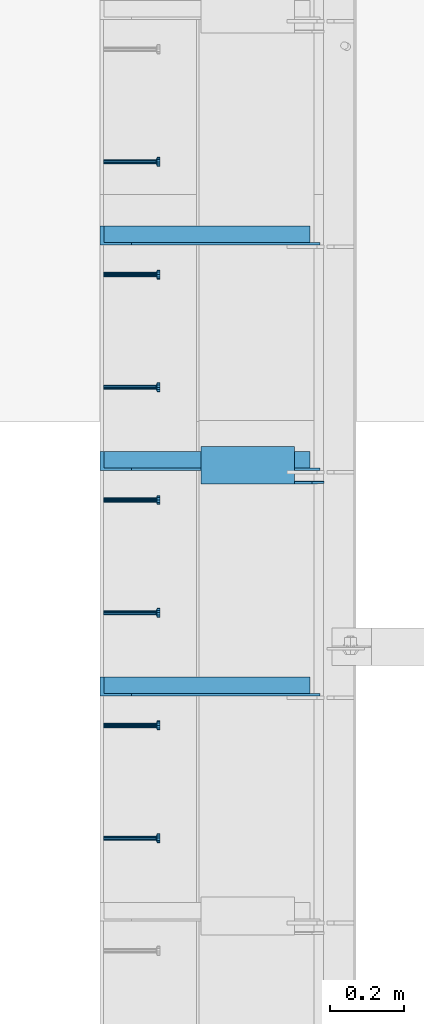
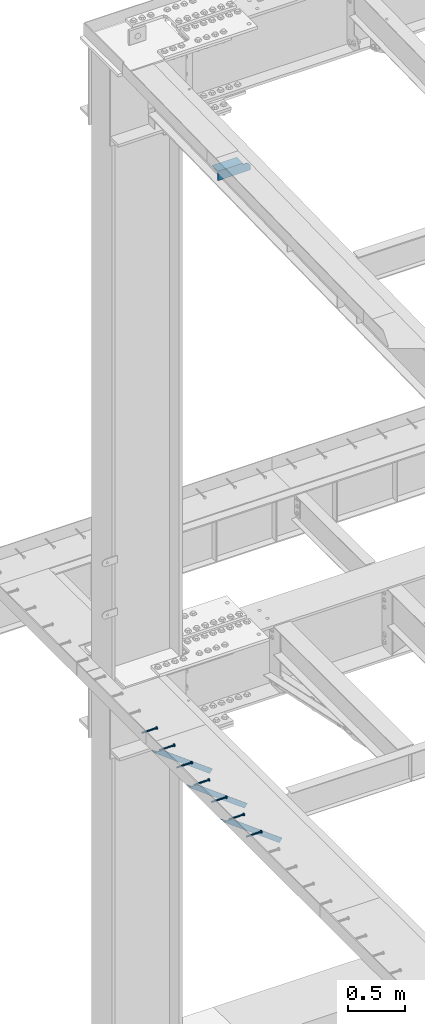
# One storey, part 1331 of 1763: 8 beams, 3 members, 9 elements without a shape of their own.
"""IFC2X3 building model written with IfcOpenShell, lengths in millimetres."""

from ifc_helpers import new_model, si_unit, frame, origin_with_axes, place, context, subcontext, project, spatial, faceted_brep, material, type_object, element, aggregate, save


model = new_model("IFC2X3")

# Units and contexts
model_context = context("Model", 3, precision=1e-05, world=origin_with_axes())
body_context = subcontext(model_context, "Body", "Model", "MODEL_VIEW")
ifc_project = project(units=[si_unit("LENGTHUNIT", "METRE", prefix="MILLI"), si_unit("AREAUNIT", "SQUARE_METRE"), si_unit("VOLUMEUNIT", "CUBIC_METRE"), si_unit("MASSUNIT", "GRAM", prefix="KILO"), si_unit("TIMEUNIT", "SECOND"), si_unit("PLANEANGLEUNIT", "RADIAN"), si_unit("SOLIDANGLEUNIT", "STERADIAN"), si_unit("THERMODYNAMICTEMPERATUREUNIT", "DEGREE_CELSIUS"), si_unit("LUMINOUSINTENSITYUNIT", "LUMEN")], contexts=[model_context])

# Site, building, storey
site_placement = place(None, origin_with_axes())
site = spatial("IfcSite", under=ifc_project, at=site_placement, CompositionType="ELEMENT")
building_placement = place(site_placement, origin_with_axes())
building = spatial("IfcBuilding", under=site, at=building_placement, Name="Undefined", CompositionType="ELEMENT")
storey_placement = place(building_placement, origin_with_axes())
storey = spatial("IfcBuildingStorey", under=building, at=storey_placement, Name="Undefined", CompositionType="ELEMENT", Elevation=0.0)

# Assembly, beam
assembly_1_placement = place(storey_placement, origin_with_axes())
assembly_1 = element("IfcElementAssembly", 1, at=assembly_1_placement, inside=storey, Name="HEADED STUD ANCHOR", AssemblyPlace="NOTDEFINED", PredefinedType="RIGID_FRAME")
ifc_material_1 = material(Name="STEEL/A108")
beam_type_1 = type_object("IfcBeamType", PredefinedType="NOTDEFINED")
beam_1_placement = place(assembly_1_placement, frame((-87975.5122736983, 49164.8750061035, 5268.91250001202), z_axis=(0.0, 0.0, -1.0), x_axis=(1.0, 0.0, 0.0)))
beam_1 = element("IfcBeam", 2, at=beam_1_placement, type_object=beam_type_1, material=ifc_material_1, Name="HEADED STUD ANCHOR", context=body_context, shape_type="Brep", body=[
    faceted_brep([(0.0, -3.1800000667572, 5.5), (0.0, -5.5, 3.1800000667572), (141.732000000002, -5.5, 3.1800000667572), (141.732000000002, -3.1800000667572, 5.5), (0.0, -6.34999999999491, 1.45519152283669e-11), (141.732000000002, -6.34999990463257, 0.0), (0.0, -5.5, -3.1800000667572), (141.732000000002, -5.5, -3.1800000667572), (0.0, -3.1800000667572, -5.5), (141.732000000002, -3.1800000667572, -5.5), (0.0, 0.0, -6.34999990463257), (141.732000000002, 0.0, -6.34999990463257), (0.0, 3.1800000667572, -5.5), (141.732000000002, 3.1800000667572, -5.5), (0.0, 5.5, -3.1800000667572), (141.732000000002, 5.5, -3.1800000667572), (0.0, 6.34999999999491, -2.91038304567337e-11), (141.732000000002, 6.34999990463257, 0.0), (0.0, 5.5, 3.1800000667572), (141.732000000002, 5.5, 3.1800000667572), (0.0, 3.1800000667572, 5.5), (141.732000000002, 3.1800000667572, 5.5), (0.0, 0.0, 6.34999990463257), (141.732000000002, 0.0, 6.34999990463257), (144.780000000001, -10.9899997711182, 6.34999990463257), (144.780000000001, -6.34000015258789, 10.9899997711182), (144.780000000001, -12.6999998092651, 0.0), (144.780000000001, -10.9899997711182, -6.34999990463257), (144.780000000001, -6.34000015258789, -10.9899997711182), (144.780000000001, 0.0, -12.6899995803833), (144.780000000001, 6.34000015258789, -10.9899997711182), (144.780000000001, 10.9899997711182, -6.34999990463257), (144.780000000001, 12.6999998092651, 0.0), (144.780000000001, 10.9899997711182, 6.34999990463257), (144.780000000001, 6.34000015258789, 10.9899997711182), (144.780000000001, 0.0, 12.6899995803833), (152.400000000001, -10.9899997711182, 6.34999990463257), (152.400000000001, -6.34000015258789, 10.9899997711182), (152.400000000001, -12.6999998092651, 0.0), (152.400000000001, -10.9899997711182, -6.34999990463257), (152.400000000001, -6.34000015258789, -10.9899997711182), (152.400000000001, 0.0, -12.6899995803833), (152.400000000001, 6.34000015258789, -10.9899997711182), (152.400000000001, 10.9899997711182, -6.34999990463257), (152.400000000001, 12.6999998092651, 0.0), (152.400000000001, 10.9899997711182, 6.34999990463257), (152.400000000001, 6.34000015258789, 10.9899997711182), (152.400000000001, 0.0, 12.6899995803833)], [[[0, 1, 2, 3]], [[1, 4, 5, 2]], [[4, 6, 7, 5]], [[6, 8, 9, 7]], [[8, 10, 11, 9]], [[10, 12, 13, 11]], [[12, 14, 15, 13]], [[14, 16, 17, 15]], [[16, 18, 19, 17]], [[18, 20, 21, 19]], [[20, 22, 23, 21]], [[22, 0, 3, 23]], [[22, 20, 18, 16, 14, 12, 10, 8, 6, 4, 1, 0]], [[3, 2, 24, 25]], [[2, 5, 26, 24]], [[5, 7, 27, 26]], [[7, 9, 28, 27]], [[9, 11, 29, 28]], [[11, 13, 30, 29]], [[13, 15, 31, 30]], [[15, 17, 32, 31]], [[17, 19, 33, 32]], [[19, 21, 34, 33]], [[21, 23, 35, 34]], [[23, 3, 25, 35]], [[25, 24, 36, 37]], [[24, 26, 38, 36]], [[26, 27, 39, 38]], [[27, 28, 40, 39]], [[28, 29, 41, 40]], [[29, 30, 42, 41]], [[30, 31, 43, 42]], [[31, 32, 44, 43]], [[32, 33, 45, 44]], [[33, 34, 46, 45]], [[34, 35, 47, 46]], [[35, 25, 37, 47]], [[38, 39, 40, 41, 42, 43, 44, 45, 46, 47, 37, 36]]]),
])
aggregate(assembly_1, [beam_1])

assembly_2_placement = place(storey_placement, origin_with_axes())
assembly_2 = element("IfcElementAssembly", 3, at=assembly_2_placement, inside=storey, Name="HEADED STUD ANCHOR", AssemblyPlace="NOTDEFINED", PredefinedType="RIGID_FRAME")
beam_2_placement = place(assembly_2_placement, frame((-87975.5122736983, 49469.6750061035, 5268.91250001202), z_axis=(0.0, 0.0, -1.0), x_axis=(1.0, 0.0, 0.0)))
beam_2 = element("IfcBeam", 4, at=beam_2_placement, type_object=beam_type_1, material=ifc_material_1, Name="HEADED STUD ANCHOR", context=body_context, shape_type="Brep", body=[
    faceted_brep([(0.0, -3.1800000667572, 5.5), (0.0, -5.5, 3.1800000667572), (141.732000000002, -5.5, 3.1800000667572), (141.732000000002, -3.1800000667572, 5.5), (0.0, -6.34999999999491, 1.45519152283669e-11), (141.732000000002, -6.34999990463257, 0.0), (0.0, -5.5, -3.1800000667572), (141.732000000002, -5.5, -3.1800000667572), (0.0, -3.1800000667572, -5.5), (141.732000000002, -3.1800000667572, -5.5), (0.0, 0.0, -6.34999990463257), (141.732000000002, 0.0, -6.34999990463257), (0.0, 3.1800000667572, -5.5), (141.732000000002, 3.1800000667572, -5.5), (0.0, 5.5, -3.1800000667572), (141.732000000002, 5.5, -3.1800000667572), (0.0, 6.34999999999491, -2.91038304567337e-11), (141.732000000002, 6.34999990463257, 0.0), (0.0, 5.5, 3.1800000667572), (141.732000000002, 5.5, 3.1800000667572), (0.0, 3.1800000667572, 5.5), (141.732000000002, 3.1800000667572, 5.5), (0.0, 0.0, 6.34999990463257), (141.732000000002, 0.0, 6.34999990463257), (144.780000000001, -10.9899997711182, 6.34999990463257), (144.780000000001, -6.34000015258789, 10.9899997711182), (144.780000000001, -12.6999998092651, 0.0), (144.780000000001, -10.9899997711182, -6.34999990463257), (144.780000000001, -6.34000015258789, -10.9899997711182), (144.780000000001, 0.0, -12.6899995803833), (144.780000000001, 6.34000015258789, -10.9899997711182), (144.780000000001, 10.9899997711182, -6.34999990463257), (144.780000000001, 12.6999998092651, 0.0), (144.780000000001, 10.9899997711182, 6.34999990463257), (144.780000000001, 6.34000015258789, 10.9899997711182), (144.780000000001, 0.0, 12.6899995803833), (152.400000000001, -10.9899997711182, 6.34999990463257), (152.400000000001, -6.34000015258789, 10.9899997711182), (152.400000000001, -12.6999998092651, 0.0), (152.400000000001, -10.9899997711182, -6.34999990463257), (152.400000000001, -6.34000015258789, -10.9899997711182), (152.400000000001, 0.0, -12.6899995803833), (152.400000000001, 6.34000015258789, -10.9899997711182), (152.400000000001, 10.9899997711182, -6.34999990463257), (152.400000000001, 12.6999998092651, 0.0), (152.400000000001, 10.9899997711182, 6.34999990463257), (152.400000000001, 6.34000015258789, 10.9899997711182), (152.400000000001, 0.0, 12.6899995803833)], [[[0, 1, 2, 3]], [[1, 4, 5, 2]], [[4, 6, 7, 5]], [[6, 8, 9, 7]], [[8, 10, 11, 9]], [[10, 12, 13, 11]], [[12, 14, 15, 13]], [[14, 16, 17, 15]], [[16, 18, 19, 17]], [[18, 20, 21, 19]], [[20, 22, 23, 21]], [[22, 0, 3, 23]], [[22, 20, 18, 16, 14, 12, 10, 8, 6, 4, 1, 0]], [[3, 2, 24, 25]], [[2, 5, 26, 24]], [[5, 7, 27, 26]], [[7, 9, 28, 27]], [[9, 11, 29, 28]], [[11, 13, 30, 29]], [[13, 15, 31, 30]], [[15, 17, 32, 31]], [[17, 19, 33, 32]], [[19, 21, 34, 33]], [[21, 23, 35, 34]], [[23, 3, 25, 35]], [[25, 24, 36, 37]], [[24, 26, 38, 36]], [[26, 27, 39, 38]], [[27, 28, 40, 39]], [[28, 29, 41, 40]], [[29, 30, 42, 41]], [[30, 31, 43, 42]], [[31, 32, 44, 43]], [[32, 33, 45, 44]], [[33, 34, 46, 45]], [[34, 35, 47, 46]], [[35, 25, 37, 47]], [[38, 39, 40, 41, 42, 43, 44, 45, 46, 47, 37, 36]]]),
])
aggregate(assembly_2, [beam_2])

assembly_3_placement = place(storey_placement, origin_with_axes())
assembly_3 = element("IfcElementAssembly", 5, at=assembly_3_placement, inside=storey, Name="HEADED STUD ANCHOR", AssemblyPlace="NOTDEFINED", PredefinedType="RIGID_FRAME")
beam_3_placement = place(assembly_3_placement, frame((-87975.5122736983, 49774.4750061035, 5268.91250001202), z_axis=(0.0, 0.0, -1.0), x_axis=(1.0, 0.0, 0.0)))
beam_3 = element("IfcBeam", 6, at=beam_3_placement, type_object=beam_type_1, material=ifc_material_1, Name="HEADED STUD ANCHOR", context=body_context, shape_type="Brep", body=[
    faceted_brep([(0.0, -3.1800000667572, 5.5), (0.0, -5.5, 3.1800000667572), (141.732000000002, -5.5, 3.1800000667572), (141.732000000002, -3.1800000667572, 5.5), (0.0, -6.34999999999491, 1.45519152283669e-11), (141.732000000002, -6.34999990463257, 0.0), (0.0, -5.5, -3.1800000667572), (141.732000000002, -5.5, -3.1800000667572), (0.0, -3.1800000667572, -5.5), (141.732000000002, -3.1800000667572, -5.5), (0.0, 0.0, -6.34999990463257), (141.732000000002, 0.0, -6.34999990463257), (0.0, 3.1800000667572, -5.5), (141.732000000002, 3.1800000667572, -5.5), (0.0, 5.5, -3.1800000667572), (141.732000000002, 5.5, -3.1800000667572), (0.0, 6.34999999999491, -2.91038304567337e-11), (141.732000000002, 6.34999990463257, 0.0), (0.0, 5.5, 3.1800000667572), (141.732000000002, 5.5, 3.1800000667572), (0.0, 3.1800000667572, 5.5), (141.732000000002, 3.1800000667572, 5.5), (0.0, 0.0, 6.34999990463257), (141.732000000002, 0.0, 6.34999990463257), (144.780000000001, -10.9899997711182, 6.34999990463257), (144.780000000001, -6.34000015258789, 10.9899997711182), (144.780000000001, -12.6999998092651, 0.0), (144.780000000001, -10.9899997711182, -6.34999990463257), (144.780000000001, -6.34000015258789, -10.9899997711182), (144.780000000001, 0.0, -12.6899995803833), (144.780000000001, 6.34000015258789, -10.9899997711182), (144.780000000001, 10.9899997711182, -6.34999990463257), (144.780000000001, 12.6999998092651, 0.0), (144.780000000001, 10.9899997711182, 6.34999990463257), (144.780000000001, 6.34000015258789, 10.9899997711182), (144.780000000001, 0.0, 12.6899995803833), (152.400000000001, -10.9899997711182, 6.34999990463257), (152.400000000001, -6.34000015258789, 10.9899997711182), (152.400000000001, -12.6999998092651, 0.0), (152.400000000001, -10.9899997711182, -6.34999990463257), (152.400000000001, -6.34000015258789, -10.9899997711182), (152.400000000001, 0.0, -12.6899995803833), (152.400000000001, 6.34000015258789, -10.9899997711182), (152.400000000001, 10.9899997711182, -6.34999990463257), (152.400000000001, 12.6999998092651, 0.0), (152.400000000001, 10.9899997711182, 6.34999990463257), (152.400000000001, 6.34000015258789, 10.9899997711182), (152.400000000001, 0.0, 12.6899995803833)], [[[0, 1, 2, 3]], [[1, 4, 5, 2]], [[4, 6, 7, 5]], [[6, 8, 9, 7]], [[8, 10, 11, 9]], [[10, 12, 13, 11]], [[12, 14, 15, 13]], [[14, 16, 17, 15]], [[16, 18, 19, 17]], [[18, 20, 21, 19]], [[20, 22, 23, 21]], [[22, 0, 3, 23]], [[22, 20, 18, 16, 14, 12, 10, 8, 6, 4, 1, 0]], [[3, 2, 24, 25]], [[2, 5, 26, 24]], [[5, 7, 27, 26]], [[7, 9, 28, 27]], [[9, 11, 29, 28]], [[11, 13, 30, 29]], [[13, 15, 31, 30]], [[15, 17, 32, 31]], [[17, 19, 33, 32]], [[19, 21, 34, 33]], [[21, 23, 35, 34]], [[23, 3, 25, 35]], [[25, 24, 36, 37]], [[24, 26, 38, 36]], [[26, 27, 39, 38]], [[27, 28, 40, 39]], [[28, 29, 41, 40]], [[29, 30, 42, 41]], [[30, 31, 43, 42]], [[31, 32, 44, 43]], [[32, 33, 45, 44]], [[33, 34, 46, 45]], [[34, 35, 47, 46]], [[35, 25, 37, 47]], [[38, 39, 40, 41, 42, 43, 44, 45, 46, 47, 37, 36]]]),
])
aggregate(assembly_3, [beam_3])

assembly_4_placement = place(storey_placement, origin_with_axes())
assembly_4 = element("IfcElementAssembly", 7, at=assembly_4_placement, inside=storey, Name="HEADED STUD ANCHOR", AssemblyPlace="NOTDEFINED", PredefinedType="RIGID_FRAME")
beam_4_placement = place(assembly_4_placement, frame((-87975.5122736983, 50079.2750061035, 5268.91250001202), z_axis=(0.0, 0.0, -1.0), x_axis=(1.0, 0.0, 0.0)))
beam_4 = element("IfcBeam", 8, at=beam_4_placement, type_object=beam_type_1, material=ifc_material_1, Name="HEADED STUD ANCHOR", context=body_context, shape_type="Brep", body=[
    faceted_brep([(0.0, -3.1800000667572, 5.5), (0.0, -5.5, 3.1800000667572), (141.732000000002, -5.5, 3.1800000667572), (141.732000000002, -3.1800000667572, 5.5), (0.0, -6.34999999999491, 1.45519152283669e-11), (141.732000000002, -6.34999990463257, 0.0), (0.0, -5.5, -3.1800000667572), (141.732000000002, -5.5, -3.1800000667572), (0.0, -3.1800000667572, -5.5), (141.732000000002, -3.1800000667572, -5.5), (0.0, 0.0, -6.34999990463257), (141.732000000002, 0.0, -6.34999990463257), (0.0, 3.1800000667572, -5.5), (141.732000000002, 3.1800000667572, -5.5), (0.0, 5.5, -3.1800000667572), (141.732000000002, 5.5, -3.1800000667572), (0.0, 6.34999999999491, -2.91038304567337e-11), (141.732000000002, 6.34999990463257, 0.0), (0.0, 5.5, 3.1800000667572), (141.732000000002, 5.5, 3.1800000667572), (0.0, 3.1800000667572, 5.5), (141.732000000002, 3.1800000667572, 5.5), (0.0, 0.0, 6.34999990463257), (141.732000000002, 0.0, 6.34999990463257), (144.780000000001, -10.9899997711182, 6.34999990463257), (144.780000000001, -6.34000015258789, 10.9899997711182), (144.780000000001, -12.6999998092651, 0.0), (144.780000000001, -10.9899997711182, -6.34999990463257), (144.780000000001, -6.34000015258789, -10.9899997711182), (144.780000000001, 0.0, -12.6899995803833), (144.780000000001, 6.34000015258789, -10.9899997711182), (144.780000000001, 10.9899997711182, -6.34999990463257), (144.780000000001, 12.6999998092651, 0.0), (144.780000000001, 10.9899997711182, 6.34999990463257), (144.780000000001, 6.34000015258789, 10.9899997711182), (144.780000000001, 0.0, 12.6899995803833), (152.400000000001, -10.9899997711182, 6.34999990463257), (152.400000000001, -6.34000015258789, 10.9899997711182), (152.400000000001, -12.6999998092651, 0.0), (152.400000000001, -10.9899997711182, -6.34999990463257), (152.400000000001, -6.34000015258789, -10.9899997711182), (152.400000000001, 0.0, -12.6899995803833), (152.400000000001, 6.34000015258789, -10.9899997711182), (152.400000000001, 10.9899997711182, -6.34999990463257), (152.400000000001, 12.6999998092651, 0.0), (152.400000000001, 10.9899997711182, 6.34999990463257), (152.400000000001, 6.34000015258789, 10.9899997711182), (152.400000000001, 0.0, 12.6899995803833)], [[[0, 1, 2, 3]], [[1, 4, 5, 2]], [[4, 6, 7, 5]], [[6, 8, 9, 7]], [[8, 10, 11, 9]], [[10, 12, 13, 11]], [[12, 14, 15, 13]], [[14, 16, 17, 15]], [[16, 18, 19, 17]], [[18, 20, 21, 19]], [[20, 22, 23, 21]], [[22, 0, 3, 23]], [[22, 20, 18, 16, 14, 12, 10, 8, 6, 4, 1, 0]], [[3, 2, 24, 25]], [[2, 5, 26, 24]], [[5, 7, 27, 26]], [[7, 9, 28, 27]], [[9, 11, 29, 28]], [[11, 13, 30, 29]], [[13, 15, 31, 30]], [[15, 17, 32, 31]], [[17, 19, 33, 32]], [[19, 21, 34, 33]], [[21, 23, 35, 34]], [[23, 3, 25, 35]], [[25, 24, 36, 37]], [[24, 26, 38, 36]], [[26, 27, 39, 38]], [[27, 28, 40, 39]], [[28, 29, 41, 40]], [[29, 30, 42, 41]], [[30, 31, 43, 42]], [[31, 32, 44, 43]], [[32, 33, 45, 44]], [[33, 34, 46, 45]], [[34, 35, 47, 46]], [[35, 25, 37, 47]], [[38, 39, 40, 41, 42, 43, 44, 45, 46, 47, 37, 36]]]),
])
aggregate(assembly_4, [beam_4])

assembly_5_placement = place(storey_placement, origin_with_axes())
assembly_5 = element("IfcElementAssembly", 9, at=assembly_5_placement, inside=storey, Name="HEADED STUD ANCHOR", AssemblyPlace="NOTDEFINED", PredefinedType="RIGID_FRAME")
beam_5_placement = place(assembly_5_placement, frame((-87975.5122736983, 50384.0750061035, 5268.91250001202), z_axis=(0.0, 0.0, -1.0), x_axis=(1.0, 0.0, 0.0)))
beam_5 = element("IfcBeam", 10, at=beam_5_placement, type_object=beam_type_1, material=ifc_material_1, Name="HEADED STUD ANCHOR", context=body_context, shape_type="Brep", body=[
    faceted_brep([(0.0, -3.1800000667572, 5.5), (0.0, -5.5, 3.1800000667572), (141.732000000002, -5.5, 3.1800000667572), (141.732000000002, -3.1800000667572, 5.5), (0.0, -6.34999999999491, 1.45519152283669e-11), (141.732000000002, -6.34999990463257, 0.0), (0.0, -5.5, -3.1800000667572), (141.732000000002, -5.5, -3.1800000667572), (0.0, -3.1800000667572, -5.5), (141.732000000002, -3.1800000667572, -5.5), (0.0, 0.0, -6.34999990463257), (141.732000000002, 0.0, -6.34999990463257), (0.0, 3.1800000667572, -5.5), (141.732000000002, 3.1800000667572, -5.5), (0.0, 5.5, -3.1800000667572), (141.732000000002, 5.5, -3.1800000667572), (0.0, 6.34999999999491, -2.91038304567337e-11), (141.732000000002, 6.34999990463257, 0.0), (0.0, 5.5, 3.1800000667572), (141.732000000002, 5.5, 3.1800000667572), (0.0, 3.1800000667572, 5.5), (141.732000000002, 3.1800000667572, 5.5), (0.0, 0.0, 6.34999990463257), (141.732000000002, 0.0, 6.34999990463257), (144.780000000001, -10.9899997711182, 6.34999990463257), (144.780000000001, -6.34000015258789, 10.9899997711182), (144.780000000001, -12.6999998092651, 0.0), (144.780000000001, -10.9899997711182, -6.34999990463257), (144.780000000001, -6.34000015258789, -10.9899997711182), (144.780000000001, 0.0, -12.6899995803833), (144.780000000001, 6.34000015258789, -10.9899997711182), (144.780000000001, 10.9899997711182, -6.34999990463257), (144.780000000001, 12.6999998092651, 0.0), (144.780000000001, 10.9899997711182, 6.34999990463257), (144.780000000001, 6.34000015258789, 10.9899997711182), (144.780000000001, 0.0, 12.6899995803833), (152.400000000001, -10.9899997711182, 6.34999990463257), (152.400000000001, -6.34000015258789, 10.9899997711182), (152.400000000001, -12.6999998092651, 0.0), (152.400000000001, -10.9899997711182, -6.34999990463257), (152.400000000001, -6.34000015258789, -10.9899997711182), (152.400000000001, 0.0, -12.6899995803833), (152.400000000001, 6.34000015258789, -10.9899997711182), (152.400000000001, 10.9899997711182, -6.34999990463257), (152.400000000001, 12.6999998092651, 0.0), (152.400000000001, 10.9899997711182, 6.34999990463257), (152.400000000001, 6.34000015258789, 10.9899997711182), (152.400000000001, 0.0, 12.6899995803833)], [[[0, 1, 2, 3]], [[1, 4, 5, 2]], [[4, 6, 7, 5]], [[6, 8, 9, 7]], [[8, 10, 11, 9]], [[10, 12, 13, 11]], [[12, 14, 15, 13]], [[14, 16, 17, 15]], [[16, 18, 19, 17]], [[18, 20, 21, 19]], [[20, 22, 23, 21]], [[22, 0, 3, 23]], [[22, 20, 18, 16, 14, 12, 10, 8, 6, 4, 1, 0]], [[3, 2, 24, 25]], [[2, 5, 26, 24]], [[5, 7, 27, 26]], [[7, 9, 28, 27]], [[9, 11, 29, 28]], [[11, 13, 30, 29]], [[13, 15, 31, 30]], [[15, 17, 32, 31]], [[17, 19, 33, 32]], [[19, 21, 34, 33]], [[21, 23, 35, 34]], [[23, 3, 25, 35]], [[25, 24, 36, 37]], [[24, 26, 38, 36]], [[26, 27, 39, 38]], [[27, 28, 40, 39]], [[28, 29, 41, 40]], [[29, 30, 42, 41]], [[30, 31, 43, 42]], [[31, 32, 44, 43]], [[32, 33, 45, 44]], [[33, 34, 46, 45]], [[34, 35, 47, 46]], [[35, 25, 37, 47]], [[38, 39, 40, 41, 42, 43, 44, 45, 46, 47, 37, 36]]]),
])
aggregate(assembly_5, [beam_5])

assembly_6_placement = place(storey_placement, origin_with_axes())
assembly_6 = element("IfcElementAssembly", 11, at=assembly_6_placement, inside=storey, Name="HEADED STUD ANCHOR", AssemblyPlace="NOTDEFINED", PredefinedType="RIGID_FRAME")
beam_6_placement = place(assembly_6_placement, frame((-87975.5122736983, 50688.8750061035, 5268.91250001202), z_axis=(0.0, 0.0, -1.0), x_axis=(1.0, 0.0, 0.0)))
beam_6 = element("IfcBeam", 12, at=beam_6_placement, type_object=beam_type_1, material=ifc_material_1, Name="HEADED STUD ANCHOR", context=body_context, shape_type="Brep", body=[
    faceted_brep([(0.0, -3.1800000667572, 5.5), (0.0, -5.5, 3.1800000667572), (141.732000000002, -5.5, 3.1800000667572), (141.732000000002, -3.1800000667572, 5.5), (0.0, -6.34999999999491, 1.45519152283669e-11), (141.732000000002, -6.34999990463257, 0.0), (0.0, -5.5, -3.1800000667572), (141.732000000002, -5.5, -3.1800000667572), (0.0, -3.1800000667572, -5.5), (141.732000000002, -3.1800000667572, -5.5), (0.0, 0.0, -6.34999990463257), (141.732000000002, 0.0, -6.34999990463257), (0.0, 3.1800000667572, -5.5), (141.732000000002, 3.1800000667572, -5.5), (0.0, 5.5, -3.1800000667572), (141.732000000002, 5.5, -3.1800000667572), (0.0, 6.34999999999491, -2.91038304567337e-11), (141.732000000002, 6.34999990463257, 0.0), (0.0, 5.5, 3.1800000667572), (141.732000000002, 5.5, 3.1800000667572), (0.0, 3.1800000667572, 5.5), (141.732000000002, 3.1800000667572, 5.5), (0.0, 0.0, 6.34999990463257), (141.732000000002, 0.0, 6.34999990463257), (144.780000000001, -10.9899997711182, 6.34999990463257), (144.780000000001, -6.34000015258789, 10.9899997711182), (144.780000000001, -12.6999998092651, 0.0), (144.780000000001, -10.9899997711182, -6.34999990463257), (144.780000000001, -6.34000015258789, -10.9899997711182), (144.780000000001, 0.0, -12.6899995803833), (144.780000000001, 6.34000015258789, -10.9899997711182), (144.780000000001, 10.9899997711182, -6.34999990463257), (144.780000000001, 12.6999998092651, 0.0), (144.780000000001, 10.9899997711182, 6.34999990463257), (144.780000000001, 6.34000015258789, 10.9899997711182), (144.780000000001, 0.0, 12.6899995803833), (152.400000000001, -10.9899997711182, 6.34999990463257), (152.400000000001, -6.34000015258789, 10.9899997711182), (152.400000000001, -12.6999998092651, 0.0), (152.400000000001, -10.9899997711182, -6.34999990463257), (152.400000000001, -6.34000015258789, -10.9899997711182), (152.400000000001, 0.0, -12.6899995803833), (152.400000000001, 6.34000015258789, -10.9899997711182), (152.400000000001, 10.9899997711182, -6.34999990463257), (152.400000000001, 12.6999998092651, 0.0), (152.400000000001, 10.9899997711182, 6.34999990463257), (152.400000000001, 6.34000015258789, 10.9899997711182), (152.400000000001, 0.0, 12.6899995803833)], [[[0, 1, 2, 3]], [[1, 4, 5, 2]], [[4, 6, 7, 5]], [[6, 8, 9, 7]], [[8, 10, 11, 9]], [[10, 12, 13, 11]], [[12, 14, 15, 13]], [[14, 16, 17, 15]], [[16, 18, 19, 17]], [[18, 20, 21, 19]], [[20, 22, 23, 21]], [[22, 0, 3, 23]], [[22, 20, 18, 16, 14, 12, 10, 8, 6, 4, 1, 0]], [[3, 2, 24, 25]], [[2, 5, 26, 24]], [[5, 7, 27, 26]], [[7, 9, 28, 27]], [[9, 11, 29, 28]], [[11, 13, 30, 29]], [[13, 15, 31, 30]], [[15, 17, 32, 31]], [[17, 19, 33, 32]], [[19, 21, 34, 33]], [[21, 23, 35, 34]], [[23, 3, 25, 35]], [[25, 24, 36, 37]], [[24, 26, 38, 36]], [[26, 27, 39, 38]], [[27, 28, 40, 39]], [[28, 29, 41, 40]], [[29, 30, 42, 41]], [[30, 31, 43, 42]], [[31, 32, 44, 43]], [[32, 33, 45, 44]], [[33, 34, 46, 45]], [[34, 35, 47, 46]], [[35, 25, 37, 47]], [[38, 39, 40, 41, 42, 43, 44, 45, 46, 47, 37, 36]]]),
])
aggregate(assembly_6, [beam_6])

assembly_7_placement = place(storey_placement, origin_with_axes())
assembly_7 = element("IfcElementAssembly", 13, at=assembly_7_placement, inside=storey, Name="HEADED STUD ANCHOR", AssemblyPlace="NOTDEFINED", PredefinedType="RIGID_FRAME")
beam_7_placement = place(assembly_7_placement, frame((-87975.5122736983, 50993.6750061035, 5268.91250001202), z_axis=(0.0, 0.0, -1.0), x_axis=(1.0, 0.0, 0.0)))
beam_7 = element("IfcBeam", 14, at=beam_7_placement, type_object=beam_type_1, material=ifc_material_1, Name="HEADED STUD ANCHOR", context=body_context, shape_type="Brep", body=[
    faceted_brep([(0.0, -3.1800000667572, 5.5), (0.0, -5.5, 3.1800000667572), (141.732000000002, -5.5, 3.1800000667572), (141.732000000002, -3.1800000667572, 5.5), (0.0, -6.34999999999491, 1.45519152283669e-11), (141.732000000002, -6.34999990463257, 0.0), (0.0, -5.5, -3.1800000667572), (141.732000000002, -5.5, -3.1800000667572), (0.0, -3.1800000667572, -5.5), (141.732000000002, -3.1800000667572, -5.5), (0.0, 0.0, -6.34999990463257), (141.732000000002, 0.0, -6.34999990463257), (0.0, 3.1800000667572, -5.5), (141.732000000002, 3.1800000667572, -5.5), (0.0, 5.5, -3.1800000667572), (141.732000000002, 5.5, -3.1800000667572), (0.0, 6.34999999999491, -2.91038304567337e-11), (141.732000000002, 6.34999990463257, 0.0), (0.0, 5.5, 3.1800000667572), (141.732000000002, 5.5, 3.1800000667572), (0.0, 3.1800000667572, 5.5), (141.732000000002, 3.1800000667572, 5.5), (0.0, 0.0, 6.34999990463257), (141.732000000002, 0.0, 6.34999990463257), (144.780000000001, -10.9899997711182, 6.34999990463257), (144.780000000001, -6.34000015258789, 10.9899997711182), (144.780000000001, -12.6999998092651, 0.0), (144.780000000001, -10.9899997711182, -6.34999990463257), (144.780000000001, -6.34000015258789, -10.9899997711182), (144.780000000001, 0.0, -12.6899995803833), (144.780000000001, 6.34000015258789, -10.9899997711182), (144.780000000001, 10.9899997711182, -6.34999990463257), (144.780000000001, 12.6999998092651, 0.0), (144.780000000001, 10.9899997711182, 6.34999990463257), (144.780000000001, 6.34000015258789, 10.9899997711182), (144.780000000001, 0.0, 12.6899995803833), (152.400000000001, -10.9899997711182, 6.34999990463257), (152.400000000001, -6.34000015258789, 10.9899997711182), (152.400000000001, -12.6999998092651, 0.0), (152.400000000001, -10.9899997711182, -6.34999990463257), (152.400000000001, -6.34000015258789, -10.9899997711182), (152.400000000001, 0.0, -12.6899995803833), (152.400000000001, 6.34000015258789, -10.9899997711182), (152.400000000001, 10.9899997711182, -6.34999990463257), (152.400000000001, 12.6999998092651, 0.0), (152.400000000001, 10.9899997711182, 6.34999990463257), (152.400000000001, 6.34000015258789, 10.9899997711182), (152.400000000001, 0.0, 12.6899995803833)], [[[0, 1, 2, 3]], [[1, 4, 5, 2]], [[4, 6, 7, 5]], [[6, 8, 9, 7]], [[8, 10, 11, 9]], [[10, 12, 13, 11]], [[12, 14, 15, 13]], [[14, 16, 17, 15]], [[16, 18, 19, 17]], [[18, 20, 21, 19]], [[20, 22, 23, 21]], [[22, 0, 3, 23]], [[22, 20, 18, 16, 14, 12, 10, 8, 6, 4, 1, 0]], [[3, 2, 24, 25]], [[2, 5, 26, 24]], [[5, 7, 27, 26]], [[7, 9, 28, 27]], [[9, 11, 29, 28]], [[11, 13, 30, 29]], [[13, 15, 31, 30]], [[15, 17, 32, 31]], [[17, 19, 33, 32]], [[19, 21, 34, 33]], [[21, 23, 35, 34]], [[23, 3, 25, 35]], [[25, 24, 36, 37]], [[24, 26, 38, 36]], [[26, 27, 39, 38]], [[27, 28, 40, 39]], [[28, 29, 41, 40]], [[29, 30, 42, 41]], [[30, 31, 43, 42]], [[31, 32, 44, 43]], [[32, 33, 45, 44]], [[33, 34, 46, 45]], [[34, 35, 47, 46]], [[35, 25, 37, 47]], [[38, 39, 40, 41, 42, 43, 44, 45, 46, 47, 37, 36]]]),
])
aggregate(assembly_7, [beam_7])

# Assembly, members
assembly_8_placement = place(storey_placement, origin_with_axes())
assembly_8 = element("IfcElementAssembly", 15, at=assembly_8_placement, inside=storey, Name="BEAM", AssemblyPlace="NOTDEFINED", PredefinedType="RIGID_FRAME")
ifc_material_2 = material(Name="STEEL/A36")
member_type = type_object("IfcMemberType", Name="L2X2X1/4", PredefinedType="NOTDEFINED")
member_1_placement = place(assembly_8_placement, frame((-87406.0995933455, 49575.24375, 4794.78284113776), z_axis=(0.597323303215295, 0.0, 0.802000543289074), x_axis=(-0.802000543289071, 0.0, 0.597323303215297)))
member_1 = element("IfcMember", 16, at=member_1_placement, type_object=member_type, material=ifc_material_2, Name="ANGLE", ObjectType="L2X2X1/4", context=body_context, shape_type="Brep", body=[
    faceted_brep([(-1.45519152283669e-11, 25.4000000000015, -25.3999999999869), (1.45519152283669e-11, 25.4000000000015, 25.3999999999796), (634.74226311341, 25.4000000000015, 25.3999999990119), (702.949257616929, 25.4000000000015, -25.4000000010055), (1.45519152283669e-11, 19.0499999999993, 25.3999999999796), (634.74226311341, 19.0500000000029, 25.3999999990119), (-7.27595761418343e-12, 19.0499999999993, -19.0499999999956), (694.423383303991, 19.0500000000029, -19.050000001007), (-7.27595761418343e-12, -25.4000000000015, -19.0499999999956), (694.423383303991, -25.4000000000015, -19.050000001007), (-1.45519152283669e-11, -25.4000000000015, -25.3999999999869), (702.949257616929, -25.4000000000015, -25.4000000010055)], [[[0, 1, 2, 3]], [[1, 4, 5, 2]], [[4, 6, 7, 5]], [[6, 8, 9, 7]], [[8, 10, 11, 9]], [[10, 0, 3, 11]], [[5, 7, 9, 11, 3, 2]], [[10, 8, 6, 4, 1, 0]]]),
])
member_2_placement = place(assembly_8_placement, frame((-87406.0995933455, 50794.44375, 4794.78284113776), z_axis=(0.597323303215295, 0.0, 0.802000543289074), x_axis=(-0.802000543289071, 0.0, 0.597323303215297)))
member_2 = element("IfcMember", 17, at=member_2_placement, type_object=member_type, material=ifc_material_2, Name="ANGLE", ObjectType="L2X2X1/4", context=body_context, shape_type="Brep", body=[
    faceted_brep([(-1.45519152283669e-11, 25.4000000000015, -25.3999999999869), (1.45519152283669e-11, 25.4000000000015, 25.3999999999796), (634.74226311341, 25.4000000000015, 25.3999999990119), (702.949257616929, 25.4000000000015, -25.4000000010055), (1.45519152283669e-11, 19.0499999999993, 25.3999999999796), (634.74226311341, 19.0500000000029, 25.3999999990119), (-7.27595761418343e-12, 19.0499999999993, -19.0499999999956), (694.423383303991, 19.0500000000029, -19.050000001007), (-7.27595761418343e-12, -25.4000000000015, -19.0499999999956), (694.423383303991, -25.4000000000015, -19.050000001007), (-1.45519152283669e-11, -25.4000000000015, -25.3999999999869), (702.949257616929, -25.4000000000015, -25.4000000010055)], [[[0, 1, 2, 3]], [[1, 4, 5, 2]], [[4, 6, 7, 5]], [[6, 8, 9, 7]], [[8, 10, 11, 9]], [[10, 0, 3, 11]], [[5, 7, 9, 11, 3, 2]], [[10, 8, 6, 4, 1, 0]]]),
])
member_3_placement = place(assembly_8_placement, frame((-87406.0995933455, 50184.84375, 4794.78284113776), z_axis=(0.597323303215295, 0.0, 0.802000543289074), x_axis=(-0.802000543289071, 0.0, 0.597323303215297)))
member_3 = element("IfcMember", 18, at=member_3_placement, type_object=member_type, material=ifc_material_2, Name="ANGLE", ObjectType="L2X2X1/4", context=body_context, shape_type="Brep", body=[
    faceted_brep([(-1.45519152283669e-11, 25.4000000000015, -25.3999999999869), (1.45519152283669e-11, 25.4000000000015, 25.3999999999796), (634.74226311341, 25.4000000000015, 25.3999999990119), (702.949257616929, 25.4000000000015, -25.4000000010055), (1.45519152283669e-11, 19.0499999999993, 25.3999999999796), (634.74226311341, 19.0500000000029, 25.3999999990119), (-7.27595761418343e-12, 19.0499999999993, -19.0499999999956), (694.423383303991, 19.0500000000029, -19.050000001007), (-7.27595761418343e-12, -25.4000000000015, -19.0499999999956), (694.423383303991, -25.4000000000015, -19.050000001007), (-1.45519152283669e-11, -25.4000000000015, -25.3999999999869), (702.949257616929, -25.4000000000015, -25.4000000010055)], [[[0, 1, 2, 3]], [[1, 4, 5, 2]], [[4, 6, 7, 5]], [[6, 8, 9, 7]], [[8, 10, 11, 9]], [[10, 0, 3, 11]], [[5, 7, 9, 11, 3, 2]], [[10, 8, 6, 4, 1, 0]]]),
])
aggregate(assembly_8, [member_1, member_2, member_3])

# Assembly, beam
assembly_9_placement = place(storey_placement, origin_with_axes())
assembly_9 = element("IfcElementAssembly", 19, at=assembly_9_placement, inside=storey, Name="BEAM", AssemblyPlace="NOTDEFINED", PredefinedType="RIGID_FRAME")
beam_type_2 = type_object("IfcBeamType", Name="L4X4X1/4", PredefinedType="NOTDEFINED")
beam_8_placement = place(assembly_9_placement, frame((-87711.9872706461, 50174.4633658244, 11656.4200870669), z_axis=(0.0, 0.0206852279954837, -0.999786037781472), x_axis=(1.0, 0.0, 0.0)))
beam_8 = element("IfcBeam", 20, at=beam_8_placement, type_object=beam_type_2, material=ifc_material_2, Name="BRACE", ObjectType="L4X4X1/4", context=body_context, shape_type="Brep", body=[
    faceted_brep([(331.787533980634, 44.4500000001281, -4.76249998546336), (300.037521174891, 44.4500000001135, -36.4878036928512), (300.037521174891, 50.8000000001412, -36.4878037045546), (331.787546948486, 50.8000000001412, -4.76249998546518), (1.96450855582952e-10, -50.8000000000338, -44.4499999999534), (2.11002770811319e-10, -50.8000000000357, -50.799999999952), (252.412497029261, -50.800000000163, -50.7999999999502), (252.412491263516, -50.800000000163, -44.4499999999534), (-3.63797880709171e-11, 50.8000000000011, -50.8000000000538), (252.41249694943, 50.8000000001412, -50.7999999999756), (252.412491188385, 44.4500000001135, -44.4499999999807), (252.41248397647, 50.8000000001339, -36.5124986658775), (252.412483981447, 44.4500000001135, -36.5124986595329), (-2.18278728425503e-11, 44.4500000000007, -44.450000000048), (-1.81898940354586e-10, 44.4500000000371, 50.7999999999374), (-1.96450855582952e-10, 50.8000000000393, 50.7999999999374), (331.787546948486, 44.4500000001353, 50.7999999999502), (331.787546948486, 50.8000000001557, 50.7999999999465)], [[[0, 1, 2, 3]], [[4, 5, 6, 7]], [[5, 8, 9, 6]], [[10, 7, 6, 9, 11, 12]], [[13, 4, 7, 10]], [[5, 4, 13, 14, 15, 8]], [[15, 14, 16, 17]], [[17, 16, 0, 3]], [[11, 9, 8, 15, 17, 3, 2]], [[12, 11, 2, 1]], [[16, 14, 13, 10, 12, 1, 0]]]),
])
aggregate(assembly_9, [beam_8])

save(model, "model.ifc")
